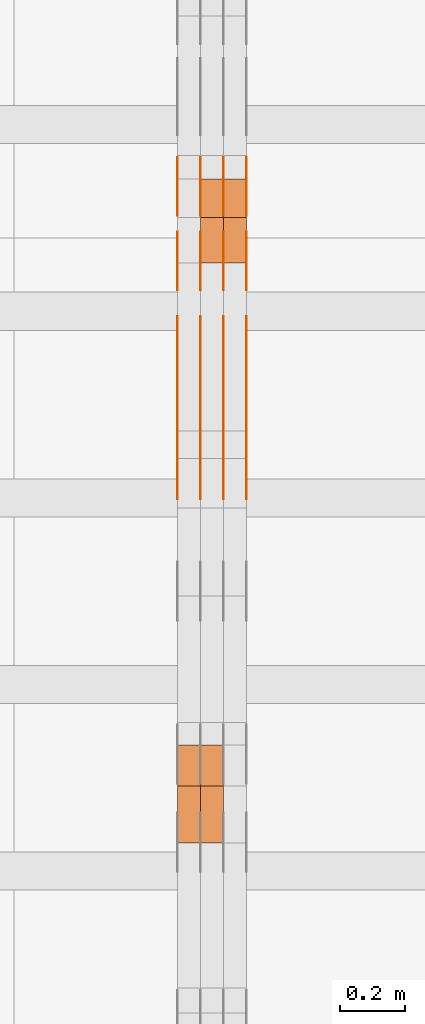
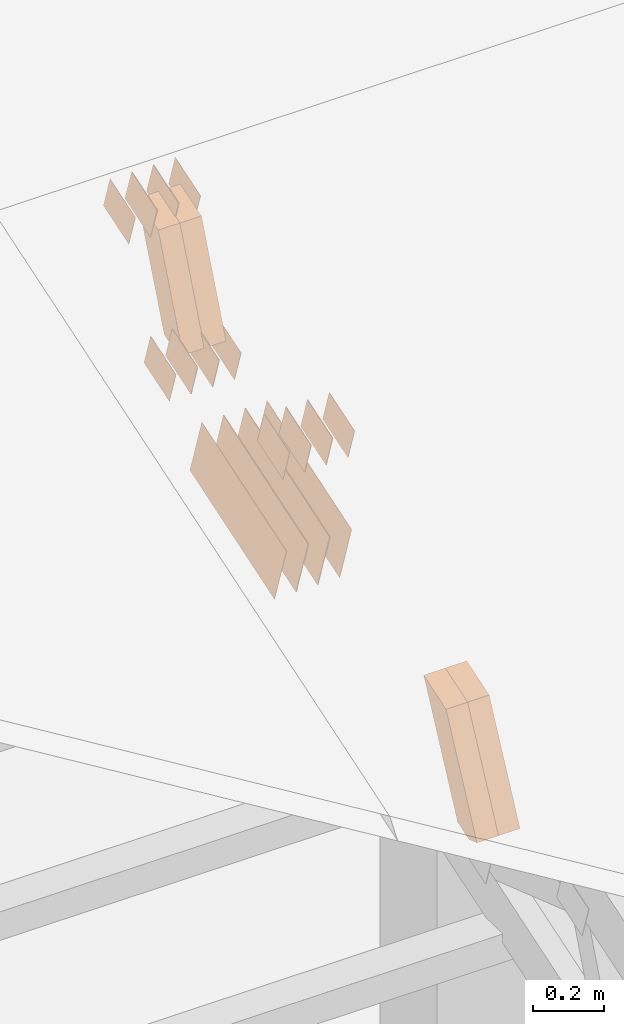
# One storey, part 257 of 385: 28 proxies.
"""IFC2X3 building model written with IfcOpenShell, lengths in millimetres."""

import ifcopenshell
import ifcopenshell.guid

model = None  # the IFC model being written
_history = None  # IfcOwnerHistory: only IFC2X3 demands one
_inside = {}  # id of a spatial element -> (the spatial element, [elements in it])
_under = {}  # id of a project, library or spatial element -> (it, [spatial elements below it])
_declared = {}  # id of a project -> (the project, [libraries it declares])
_typed = {}  # id of a type object -> (the type object, [elements of that type])
_made_of = {}  # id of a material, layer set ... -> (it, [elements and type objects made of it])


def new_model(schema):
    """Start an empty IFC model of exactly this schema.

    Asked for "IFC4X3", IfcOpenShell would pick the latest addendum, in which some entities
    have other attributes; the version numbers below select the first issue.
    IFC2X3 requires an IfcOwnerHistory on every rooted entity: one is made here for all.
    """
    global model, _history
    if schema == "IFC4X3":
        model = ifcopenshell.file(schema_version=(4, 3, 0, 0))
    else:
        model = ifcopenshell.file(schema=schema)
    _inside.clear()
    _under.clear()
    _declared.clear()
    _typed.clear()
    _made_of.clear()
    _history = None
    if model.schema == "IFC2X3":
        org = make("IfcOrganization", Name="unknown")
        user = make(
            "IfcPersonAndOrganization",
            ThePerson=make("IfcPerson", FamilyName="unknown"),
            TheOrganization=org,
        )
        app = make(
            "IfcApplication",
            ApplicationDeveloper=org,
            Version="unknown",
            ApplicationFullName="unknown",
            ApplicationIdentifier="unknown",
        )
        _history = make(
            "IfcOwnerHistory",
            OwningUser=user,
            OwningApplication=app,
            ChangeAction="ADDED",
            CreationDate=0,
        )
    return model


def make(cls, **values):
    """One entity of the class cls with the attributes given. An attribute that is None is left unset."""
    return model.create_entity(
        cls, **{name: value for name, value in values.items() if value is not None}
    )


def entity(cls, *values):
    """Any entity or typed value of the class cls, its attributes in the order of the schema. None: left unset."""
    e = model.create_entity(cls)
    for i, value in enumerate(values):
        if value is not None:
            e[i] = value
    return e


def rooted(cls, **values):
    """An entity with a GlobalId (a new one), such as an element, a storey or a relation."""
    return make(cls, GlobalId=ifcopenshell.guid.new(), OwnerHistory=_history, **values)


def si_unit(unit_type, name, prefix=None):
    """IfcSIUnit, for example si_unit("LENGTHUNIT", "METRE", prefix="MILLI")."""
    return make("IfcSIUnit", UnitType=unit_type, Prefix=prefix, Name=name)


def converted_unit(unit_type, name, factor, base, dimensions=None, offset=None):
    """IfcConversionBasedUnit, such as the inch: factor (a typed value) times the base unit."""
    return make(
        "IfcConversionBasedUnit"
        if offset is None
        else "IfcConversionBasedUnitWithOffset",
        ConversionOffset=offset,
        Dimensions=None
        if dimensions is None
        else entity("IfcDimensionalExponents", *dimensions),
        UnitType=unit_type,
        Name=name,
        ConversionFactor=make(
            "IfcMeasureWithUnit", ValueComponent=factor, UnitComponent=base
        ),
    )


def derived_unit(unit_type, elements):
    """IfcDerivedUnit: a product of units, each with its exponent."""
    return make(
        "IfcDerivedUnit",
        Elements=[
            make("IfcDerivedUnitElement", Unit=unit, Exponent=power)
            for unit, power in elements
        ],
        UnitType=unit_type,
    )


def assignment(units):
    """IfcUnitAssignment: the units of a project."""
    return None if units is None else make("IfcUnitAssignment", Units=units)


def point(xyz):
    """IfcCartesianPoint."""
    return None if xyz is None else make("IfcCartesianPoint", Coordinates=xyz)


def direction(xyz):
    """IfcDirection."""
    return None if xyz is None else make("IfcDirection", DirectionRatios=xyz)


def frame(location, z_axis=None, x_axis=None):
    """IfcAxis2Placement3D, a coordinate frame: its origin and axes. An axis left out is left unset."""
    return make(
        "IfcAxis2Placement3D",
        Location=point(location),
        Axis=direction(z_axis),
        RefDirection=direction(x_axis),
    )


def origin():
    """The frame at (0, 0, 0) with its axes left unset."""
    return frame((0.0, 0.0, 0.0))


def place(relative_to, where):
    """IfcLocalPlacement: puts the frame where relative to a parent placement (None: the world)."""
    return make(
        "IfcLocalPlacement", PlacementRelTo=relative_to, RelativePlacement=where
    )


def context(
    kind, dimensions, precision=None, world=None, true_north=None, identifier=None
):
    """IfcGeometricRepresentationContext, for example the 3D "Model" context."""
    return make(
        "IfcGeometricRepresentationContext",
        ContextIdentifier=identifier,
        ContextType=kind,
        CoordinateSpaceDimension=dimensions,
        Precision=precision,
        WorldCoordinateSystem=world,
        TrueNorth=true_north,
    )


def subcontext(parent, identifier, kind, view, scale=None):
    """IfcGeometricRepresentationSubContext, for example "Body" below "Model"."""
    return make(
        "IfcGeometricRepresentationSubContext",
        ContextIdentifier=identifier,
        ContextType=kind,
        ParentContext=parent,
        TargetScale=scale,
        TargetView=view,
    )


def project(units=None, contexts=None):
    """IfcProject with its units and contexts."""
    return rooted(
        "IfcProject",
        Name="project",
        RepresentationContexts=contexts,
        UnitsInContext=assignment(units),
    )


def spatial(cls, under=None, at=None, **own):
    """A site, building, storey or space (cls), placed at a placement, below another one or the project."""
    s = rooted(cls, ObjectPlacement=at, **own)
    if under is not None:
        _under.setdefault(under.id(), (under, []))[1].append(s)
    return s


def polyline(points):
    """IfcPolyline through the points."""
    return make("IfcPolyline", Points=[point(p) for p in points])


def outline(outer, holes=None, kind="AREA"):
    """IfcArbitraryClosedProfileDef: a profile drawn as a closed curve; with holes, ...WithVoids."""
    if holes is None:
        return make("IfcArbitraryClosedProfileDef", ProfileType=kind, OuterCurve=outer)
    return make(
        "IfcArbitraryProfileDefWithVoids",
        ProfileType=kind,
        OuterCurve=outer,
        InnerCurves=holes,
    )


def extrude(swept, where, along, depth):
    """IfcExtrudedAreaSolid: the profile swept, set in the frame where, extruded along a direction by depth."""
    return make(
        "IfcExtrudedAreaSolid",
        SweptArea=swept,
        Position=where,
        ExtrudedDirection=direction(along),
        Depth=depth,
    )


def shape(context_of_items, identifier, shape_type, items):
    """IfcShapeRepresentation: the items that make up one representation, for example the "Body"."""
    return make(
        "IfcShapeRepresentation",
        ContextOfItems=context_of_items,
        RepresentationIdentifier=identifier,
        RepresentationType=shape_type,
        Items=items,
    )


def source(mapping_origin, context_of_items, identifier, shape_type, items):
    """IfcRepresentationMap: a shape defined once, which mapped items show again and again."""
    return make(
        "IfcRepresentationMap",
        MappingOrigin=mapping_origin,
        MappedRepresentation=shape(context_of_items, identifier, shape_type, items),
    )


def transform(
    local_origin,
    x_axis=None,
    y_axis=None,
    z_axis=None,
    scale=None,
    scale2=None,
    scale3=None,
    uniform=True,
):
    """IfcCartesianTransformationOperator3D, or its non-uniform kind. x_axis, y_axis, z_axis: its Axis1, 2, 3."""
    if uniform:
        return make(
            "IfcCartesianTransformationOperator3D",
            Axis1=direction(x_axis),
            Axis2=direction(y_axis),
            LocalOrigin=point(local_origin),
            Scale=scale,
            Axis3=direction(z_axis),
        )
    return make(
        "IfcCartesianTransformationOperator3DnonUniform",
        Axis1=direction(x_axis),
        Axis2=direction(y_axis),
        LocalOrigin=point(local_origin),
        Scale=scale,
        Axis3=direction(z_axis),
        Scale2=scale2,
        Scale3=scale3,
    )


def mapped(mapping_source, mapping_target):
    """IfcMappedItem: shows the shape of a source again, moved by a transform."""
    return make(
        "IfcMappedItem", MappingSource=mapping_source, MappingTarget=mapping_target
    )


def material(Name=None, Category=None):
    """IfcMaterial."""
    return make("IfcMaterial", Name=Name, Category=Category)


def made_of(thing, what):
    """Note that an element or type object is made of a material, layer set ...; save() writes the relation."""
    if what is not None:
        _made_of.setdefault(what.id(), (what, []))[1].append(thing)
    return thing


def type_object(cls, material=None, **own):
    """A type object (cls), such as IfcWallType, which elements share."""
    return made_of(rooted(cls, **own), material)


def type_shapes(of_type, sources):
    """Give a type object the sources (RepresentationMaps) that its elements show as mapped items."""
    of_type.RepresentationMaps = sources


def element(
    cls,
    number,
    at=None,
    inside=None,
    cuts=None,
    type_object=None,
    material=None,
    context=None,
    identifier="Body",
    shape_type=None,
    held_by="IfcProductDefinitionShape",
    body=None,
    shapes=None,
    **own,
):
    """One element of the class cls, such as IfcWall. Its Tag is "e" and its number.

    at: its placement. inside: the storey or other place that contains it. cuts: it is an
    opening in that element (IfcRelVoidsElement). A single representation is given by context,
    identifier, shape_type and body (its items); several are given by shapes. held_by: the class
    of the entity that holds the representations. save() writes the other relations.
    """
    e = rooted(cls, Tag="e%d" % number, ObjectPlacement=at, **own)
    if body is not None:
        shapes = [shape(context, identifier, shape_type, body)]
    if shapes is not None:
        e.Representation = make(held_by, Representations=shapes)
    if inside is not None:
        _inside.setdefault(inside.id(), (inside, []))[1].append(e)
    if cuts is not None:
        rooted(
            "IfcRelVoidsElement", RelatingBuildingElement=cuts, RelatedOpeningElement=e
        )
    if type_object is not None:
        _typed.setdefault(type_object.id(), (type_object, []))[1].append(e)
    return made_of(e, material)


def aggregate(whole, parts):
    """IfcRelAggregates: a whole, such as a stair, and the parts it consists of."""
    return rooted("IfcRelAggregates", RelatingObject=whole, RelatedObjects=parts)


def save(model, path):
    """Write the relations noted so far, then the file.

    IfcRelAggregates (storeys below a building ...), IfcRelContainedInSpatialStructure (elements
    in a storey), IfcRelDefinesByType, IfcRelAssociatesMaterial and IfcRelDeclares: one each for
    every whole, place, type object, material and project.
    """
    for whole, parts in _under.values():
        aggregate(whole, parts)
    for where, things in _inside.values():
        rooted(
            "IfcRelContainedInSpatialStructure",
            RelatedElements=things,
            RelatingStructure=where,
        )
    for kind, things in _typed.values():
        rooted("IfcRelDefinesByType", RelatedObjects=things, RelatingType=kind)
    for what, things in _made_of.values():
        rooted("IfcRelAssociatesMaterial", RelatedObjects=things, RelatingMaterial=what)
    for by, libraries in _declared.values():
        rooted("IfcRelDeclares", RelatingContext=by, RelatedDefinitions=libraries)
    model.write(path)


model = new_model("IFC2X3")

# Units and contexts
model_context = context("Model", 3, precision=0.01, world=origin(), true_north=direction((6.12303176911189e-17, 1.0)))
body_context = subcontext(model_context, "Body", "Model", "MODEL_VIEW")
ifc_project = project(units=[si_unit("LENGTHUNIT", "METRE", prefix="MILLI"), si_unit("AREAUNIT", "SQUARE_METRE"), si_unit("VOLUMEUNIT", "CUBIC_METRE"), converted_unit("PLANEANGLEUNIT", "DEGREE", entity("IfcRatioMeasure", 0.0174532925199433), si_unit("PLANEANGLEUNIT", "RADIAN"), dimensions=[0, 0, 0, 0, 0, 0, 0]), si_unit("MASSUNIT", "GRAM", prefix="KILO"), derived_unit("MASSDENSITYUNIT", [(si_unit("MASSUNIT", "GRAM", prefix="KILO"), 1), (si_unit("LENGTHUNIT", "METRE"), -3)]), si_unit("TIMEUNIT", "SECOND"), si_unit("FREQUENCYUNIT", "HERTZ"), si_unit("THERMODYNAMICTEMPERATUREUNIT", "DEGREE_CELSIUS"), derived_unit("THERMALTRANSMITTANCEUNIT", [(si_unit("MASSUNIT", "GRAM", prefix="KILO"), 1), (si_unit("THERMODYNAMICTEMPERATUREUNIT", "KELVIN"), -1), (si_unit("TIMEUNIT", "SECOND"), -3)]), derived_unit("VOLUMETRICFLOWRATEUNIT", [(si_unit("LENGTHUNIT", "METRE"), 3), (si_unit("TIMEUNIT", "SECOND"), -1)]), si_unit("ELECTRICCURRENTUNIT", "AMPERE"), si_unit("ELECTRICVOLTAGEUNIT", "VOLT"), si_unit("POWERUNIT", "WATT"), si_unit("FORCEUNIT", "NEWTON", prefix="KILO"), si_unit("ILLUMINANCEUNIT", "LUX"), si_unit("LUMINOUSFLUXUNIT", "LUMEN"), si_unit("LUMINOUSINTENSITYUNIT", "CANDELA"), derived_unit("USERDEFINED", [(si_unit("MASSUNIT", "GRAM", prefix="KILO"), -1), (si_unit("LENGTHUNIT", "METRE"), -2), (si_unit("TIMEUNIT", "SECOND"), 3), (si_unit("LUMINOUSFLUXUNIT", "LUMEN"), 1)]), derived_unit("LINEARVELOCITYUNIT", [(si_unit("LENGTHUNIT", "METRE"), 1), (si_unit("TIMEUNIT", "SECOND"), -1)]), si_unit("PRESSUREUNIT", "PASCAL"), derived_unit("USERDEFINED", [(si_unit("LENGTHUNIT", "METRE"), -2), (si_unit("MASSUNIT", "GRAM", prefix="KILO"), 1), (si_unit("TIMEUNIT", "SECOND"), -2)])], contexts=[model_context])

# Site, building, storey
site_placement = place(None, origin())
site = spatial("IfcSite", under=ifc_project, at=site_placement, CompositionType="ELEMENT")
building_placement = place(site_placement, origin())
building = spatial("IfcBuilding", under=site, at=building_placement, CompositionType="ELEMENT")
storey_placement = place(building_placement, origin())
storey = spatial("IfcBuildingStorey", under=building, at=storey_placement, Name="Default", CompositionType="ELEMENT", Elevation=0.0)

# Proxies
ifc_material_1 = material(Name="IfcSurfaceStyle #453926")
building_element_proxy_type_1 = type_object("IfcBuildingElementProxyType", PredefinedType="NOTDEFINED", material=ifc_material_1)
shared_shape_1 = source(origin(), body_context, "Body", "SweptSolid", [
    extrude(outline(polyline([(-74.9998565677179, -60.000059685226), (74.9998794200128, -60.000059685226), (74.9998565677179, 60.000059685226), (-74.9998794200128, 60.000059685226), (-74.9998565677179, -60.000059685226)])), frame((75.0001976720505, 60.000059685226, 0.0), z_axis=(0.0, 0.0, 1.0), x_axis=(-1.0, 0.0, 0.0)), (0.0, 0.0, 1.0), 1.3),
])
type_shapes(building_element_proxy_type_1, [shared_shape_1])
proxy_1_placement = place(building_placement, frame((36386.3, 8537.53090236182, 1950.11166041942), z_axis=(-1.0, 0.0, 0.0), x_axis=(0.0, 0.951056516295124, 0.309016994375039)))
element("IfcBuildingElementProxy", 1, at=proxy_1_placement, inside=storey, type_object=building_element_proxy_type_1, material=ifc_material_1, context=body_context, shape_type="MappedRepresentation", body=[
    mapped(shared_shape_1, transform((0.0, 0.0, 0.0), scale=1.0)),
])
ifc_material_2 = material(Name="IfcSurfaceStyle #453869")
building_element_proxy_type_2 = type_object("IfcBuildingElementProxyType", PredefinedType="NOTDEFINED", material=ifc_material_2)
shared_shape_2 = source(origin(), body_context, "Body", "SweptSolid", [
    extrude(outline(polyline([(-74.9998565677179, -60.000059685226), (74.9998794200128, -60.000059685226), (74.9998565677179, 60.000059685226), (-74.9998794200128, 60.000059685226), (-74.9998565677179, -60.000059685226)])), frame((75.0001976720505, 60.000059685226, 0.0), z_axis=(0.0, 0.0, 1.0), x_axis=(-1.0, 0.0, 0.0)), (0.0, 0.0, 1.0), 1.3),
])
type_shapes(building_element_proxy_type_2, [shared_shape_2])
proxy_2_placement = place(building_placement, frame((36315.0, 8537.53090236182, 1950.11166041942), z_axis=(-1.0, 0.0, 0.0), x_axis=(0.0, 0.951056516295124, 0.309016994375039)))
element("IfcBuildingElementProxy", 2, at=proxy_2_placement, inside=storey, type_object=building_element_proxy_type_2, material=ifc_material_2, context=body_context, shape_type="MappedRepresentation", body=[
    mapped(shared_shape_2, transform((0.0, 0.0, 0.0), scale=1.0)),
])
ifc_material_3 = material(Name="IfcSurfaceStyle #453812")
building_element_proxy_type_3 = type_object("IfcBuildingElementProxyType", PredefinedType="NOTDEFINED", material=ifc_material_3)
shared_shape_3 = source(origin(), body_context, "Body", "SweptSolid", [
    extrude(outline(polyline([(-74.9998565677179, -60.000059685226), (74.9998794200128, -60.000059685226), (74.9998565677179, 60.000059685226), (-74.9998794200128, 60.000059685226), (-74.9998565677179, -60.000059685226)])), frame((75.0001976720505, 60.000059685226, 0.0), z_axis=(0.0, 0.0, 1.0), x_axis=(-1.0, 0.0, 0.0)), (0.0, 0.0, 1.0), 1.3),
])
type_shapes(building_element_proxy_type_3, [shared_shape_3])
proxy_3_placement = place(building_placement, frame((36316.3, 8537.53090236182, 1950.11166041942), z_axis=(-1.0, 0.0, 0.0), x_axis=(0.0, 0.951056516295124, 0.309016994375039)))
element("IfcBuildingElementProxy", 3, at=proxy_3_placement, inside=storey, type_object=building_element_proxy_type_3, material=ifc_material_3, context=body_context, shape_type="MappedRepresentation", body=[
    mapped(shared_shape_3, transform((0.0, 0.0, 0.0), scale=1.0)),
])
ifc_material_4 = material(Name="IfcSurfaceStyle #453755")
building_element_proxy_type_4 = type_object("IfcBuildingElementProxyType", PredefinedType="NOTDEFINED", material=ifc_material_4)
shared_shape_4 = source(origin(), body_context, "Body", "SweptSolid", [
    extrude(outline(polyline([(-74.9998565677179, -60.000059685226), (74.9998794200128, -60.000059685226), (74.9998565677179, 60.000059685226), (-74.9998794200128, 60.000059685226), (-74.9998565677179, -60.000059685226)])), frame((75.0001976720505, 60.000059685226, 0.0), z_axis=(0.0, 0.0, 1.0), x_axis=(-1.0, 0.0, 0.0)), (0.0, 0.0, 1.0), 1.29999999999999),
])
type_shapes(building_element_proxy_type_4, [shared_shape_4])
proxy_4_placement = place(building_placement, frame((36245.0, 8537.53090236182, 1950.11166041942), z_axis=(-1.0, 0.0, 0.0), x_axis=(0.0, 0.951056516295124, 0.309016994375039)))
element("IfcBuildingElementProxy", 4, at=proxy_4_placement, inside=storey, type_object=building_element_proxy_type_4, material=ifc_material_4, context=body_context, shape_type="MappedRepresentation", body=[
    mapped(shared_shape_4, transform((0.0, 0.0, 0.0), scale=1.0)),
])
ifc_material_5 = material(Name="IfcSurfaceStyle #453698")
building_element_proxy_type_5 = type_object("IfcBuildingElementProxyType", PredefinedType="NOTDEFINED", material=ifc_material_5)
shared_shape_5 = source(origin(), body_context, "Body", "SweptSolid", [
    extrude(outline(polyline([(-74.9998565677179, -60.000059685226), (74.9998794200128, -60.000059685226), (74.9998565677179, 60.000059685226), (-74.9998794200128, 60.000059685226), (-74.9998565677179, -60.000059685226)])), frame((75.0001976720505, 60.000059685226, 0.0), z_axis=(0.0, 0.0, 1.0), x_axis=(-1.0, 0.0, 0.0)), (0.0, 0.0, 1.0), 1.29999999999999),
])
type_shapes(building_element_proxy_type_5, [shared_shape_5])
proxy_5_placement = place(building_placement, frame((36246.3, 8537.53090236182, 1950.11166041942), z_axis=(-1.0, 0.0, 0.0), x_axis=(0.0, 0.951056516295124, 0.309016994375039)))
element("IfcBuildingElementProxy", 5, at=proxy_5_placement, inside=storey, type_object=building_element_proxy_type_5, material=ifc_material_5, context=body_context, shape_type="MappedRepresentation", body=[
    mapped(shared_shape_5, transform((0.0, 0.0, 0.0), scale=1.0)),
])
ifc_material_6 = material(Name="IfcSurfaceStyle #453641")
building_element_proxy_type_6 = type_object("IfcBuildingElementProxyType", PredefinedType="NOTDEFINED", material=ifc_material_6)
shared_shape_6 = source(origin(), body_context, "Body", "SweptSolid", [
    extrude(outline(polyline([(-74.9998565677179, -60.000059685226), (74.9998794200128, -60.000059685226), (74.9998565677179, 60.000059685226), (-74.9998794200128, 60.000059685226), (-74.9998565677179, -60.000059685226)])), frame((75.0001976720505, 60.000059685226, 0.0), z_axis=(0.0, 0.0, 1.0), x_axis=(-1.0, 0.0, 0.0)), (0.0, 0.0, 1.0), 1.29999999999999),
])
type_shapes(building_element_proxy_type_6, [shared_shape_6])
proxy_6_placement = place(building_placement, frame((36175.0, 8537.53090236182, 1950.11166041942), z_axis=(-1.0, 0.0, 0.0), x_axis=(0.0, 0.951056516295124, 0.309016994375039)))
element("IfcBuildingElementProxy", 6, at=proxy_6_placement, inside=storey, type_object=building_element_proxy_type_6, material=ifc_material_6, context=body_context, shape_type="MappedRepresentation", body=[
    mapped(shared_shape_6, transform((0.0, 0.0, 0.0), scale=1.0)),
])
ifc_material_7 = material(Name="IfcSurfaceStyle #453584")
building_element_proxy_type_7 = type_object("IfcBuildingElementProxyType", PredefinedType="NOTDEFINED", material=ifc_material_7)
shared_shape_7 = source(origin(), body_context, "Body", "SweptSolid", [
    extrude(outline(polyline([(-74.9998754286225, -60.0000016373515), (74.9998605591045, -60.0000016373515), (74.9998754286225, 60.0000016373515), (-74.9998605591045, 60.0000016373515), (-74.9998754286225, -60.0000016373515)])), frame((74.9998754286225, 60.0000016373515, 0.0), z_axis=(0.0, 0.0, 1.0), x_axis=(-1.0, 0.0, 0.0)), (0.0, 0.0, 1.0), 1.3),
])
type_shapes(building_element_proxy_type_7, [shared_shape_7])
proxy_7_placement = place(building_placement, frame((36386.3, 8765.47458614632, 2350.86432930304), z_axis=(-1.0, 0.0, 0.0), x_axis=(0.0, 0.951056516295154, 0.309016994374948)))
element("IfcBuildingElementProxy", 7, at=proxy_7_placement, inside=storey, type_object=building_element_proxy_type_7, material=ifc_material_7, context=body_context, shape_type="MappedRepresentation", body=[
    mapped(shared_shape_7, transform((0.0, 0.0, 0.0), scale=1.0)),
])
ifc_material_8 = material(Name="IfcSurfaceStyle #453527")
building_element_proxy_type_8 = type_object("IfcBuildingElementProxyType", PredefinedType="NOTDEFINED", material=ifc_material_8)
shared_shape_8 = source(origin(), body_context, "Body", "SweptSolid", [
    extrude(outline(polyline([(-74.9998754286225, -60.0000016373515), (74.9998605591045, -60.0000016373515), (74.9998754286225, 60.0000016373515), (-74.9998605591045, 60.0000016373515), (-74.9998754286225, -60.0000016373515)])), frame((74.9998754286225, 60.0000016373515, 0.0), z_axis=(0.0, 0.0, 1.0), x_axis=(-1.0, 0.0, 0.0)), (0.0, 0.0, 1.0), 1.3),
])
type_shapes(building_element_proxy_type_8, [shared_shape_8])
proxy_8_placement = place(building_placement, frame((36315.0, 8765.47458614632, 2350.86432930304), z_axis=(-1.0, 0.0, 0.0), x_axis=(0.0, 0.951056516295154, 0.309016994374948)))
element("IfcBuildingElementProxy", 8, at=proxy_8_placement, inside=storey, type_object=building_element_proxy_type_8, material=ifc_material_8, context=body_context, shape_type="MappedRepresentation", body=[
    mapped(shared_shape_8, transform((0.0, 0.0, 0.0), scale=1.0)),
])
ifc_material_9 = material(Name="IfcSurfaceStyle #453470")
building_element_proxy_type_9 = type_object("IfcBuildingElementProxyType", PredefinedType="NOTDEFINED", material=ifc_material_9)
shared_shape_9 = source(origin(), body_context, "Body", "SweptSolid", [
    extrude(outline(polyline([(-74.9998754286225, -60.0000016373515), (74.9998605591045, -60.0000016373515), (74.9998754286225, 60.0000016373515), (-74.9998605591045, 60.0000016373515), (-74.9998754286225, -60.0000016373515)])), frame((74.9998754286225, 60.0000016373515, 0.0), z_axis=(0.0, 0.0, 1.0), x_axis=(-1.0, 0.0, 0.0)), (0.0, 0.0, 1.0), 1.3),
])
type_shapes(building_element_proxy_type_9, [shared_shape_9])
proxy_9_placement = place(building_placement, frame((36316.3, 8765.47458614632, 2350.86432930304), z_axis=(-1.0, 0.0, 0.0), x_axis=(0.0, 0.951056516295154, 0.309016994374948)))
element("IfcBuildingElementProxy", 9, at=proxy_9_placement, inside=storey, type_object=building_element_proxy_type_9, material=ifc_material_9, context=body_context, shape_type="MappedRepresentation", body=[
    mapped(shared_shape_9, transform((0.0, 0.0, 0.0), scale=1.0)),
])
ifc_material_10 = material(Name="IfcSurfaceStyle #453413")
building_element_proxy_type_10 = type_object("IfcBuildingElementProxyType", PredefinedType="NOTDEFINED", material=ifc_material_10)
shared_shape_10 = source(origin(), body_context, "Body", "SweptSolid", [
    extrude(outline(polyline([(-74.9998754286225, -60.0000016373515), (74.9998605591045, -60.0000016373515), (74.9998754286225, 60.0000016373515), (-74.9998605591045, 60.0000016373515), (-74.9998754286225, -60.0000016373515)])), frame((74.9998754286225, 60.0000016373515, 0.0), z_axis=(0.0, 0.0, 1.0), x_axis=(-1.0, 0.0, 0.0)), (0.0, 0.0, 1.0), 1.29999999999999),
])
type_shapes(building_element_proxy_type_10, [shared_shape_10])
proxy_10_placement = place(building_placement, frame((36245.0, 8765.47458614632, 2350.86432930304), z_axis=(-1.0, 0.0, 0.0), x_axis=(0.0, 0.951056516295154, 0.309016994374948)))
element("IfcBuildingElementProxy", 10, at=proxy_10_placement, inside=storey, type_object=building_element_proxy_type_10, material=ifc_material_10, context=body_context, shape_type="MappedRepresentation", body=[
    mapped(shared_shape_10, transform((0.0, 0.0, 0.0), scale=1.0)),
])
ifc_material_11 = material(Name="IfcSurfaceStyle #453356")
building_element_proxy_type_11 = type_object("IfcBuildingElementProxyType", PredefinedType="NOTDEFINED", material=ifc_material_11)
shared_shape_11 = source(origin(), body_context, "Body", "SweptSolid", [
    extrude(outline(polyline([(-74.9998754286225, -60.0000016373515), (74.9998605591045, -60.0000016373515), (74.9998754286225, 60.0000016373515), (-74.9998605591045, 60.0000016373515), (-74.9998754286225, -60.0000016373515)])), frame((74.9998754286225, 60.0000016373515, 0.0), z_axis=(0.0, 0.0, 1.0), x_axis=(-1.0, 0.0, 0.0)), (0.0, 0.0, 1.0), 1.29999999999999),
])
type_shapes(building_element_proxy_type_11, [shared_shape_11])
proxy_11_placement = place(building_placement, frame((36246.3, 8765.47458614632, 2350.86432930304), z_axis=(-1.0, 0.0, 0.0), x_axis=(0.0, 0.951056516295154, 0.309016994374948)))
element("IfcBuildingElementProxy", 11, at=proxy_11_placement, inside=storey, type_object=building_element_proxy_type_11, material=ifc_material_11, context=body_context, shape_type="MappedRepresentation", body=[
    mapped(shared_shape_11, transform((0.0, 0.0, 0.0), scale=1.0)),
])
ifc_material_12 = material(Name="IfcSurfaceStyle #453299")
building_element_proxy_type_12 = type_object("IfcBuildingElementProxyType", PredefinedType="NOTDEFINED", material=ifc_material_12)
shared_shape_12 = source(origin(), body_context, "Body", "SweptSolid", [
    extrude(outline(polyline([(-74.9998754286225, -60.0000016373515), (74.9998605591045, -60.0000016373515), (74.9998754286225, 60.0000016373515), (-74.9998605591045, 60.0000016373515), (-74.9998754286225, -60.0000016373515)])), frame((74.9998754286225, 60.0000016373515, 0.0), z_axis=(0.0, 0.0, 1.0), x_axis=(-1.0, 0.0, 0.0)), (0.0, 0.0, 1.0), 1.29999999999999),
])
type_shapes(building_element_proxy_type_12, [shared_shape_12])
proxy_12_placement = place(building_placement, frame((36175.0, 8765.47458614632, 2350.86432930304), z_axis=(-1.0, 0.0, 0.0), x_axis=(0.0, 0.951056516295154, 0.309016994374948)))
element("IfcBuildingElementProxy", 12, at=proxy_12_placement, inside=storey, type_object=building_element_proxy_type_12, material=ifc_material_12, context=body_context, shape_type="MappedRepresentation", body=[
    mapped(shared_shape_12, transform((0.0, 0.0, 0.0), scale=1.0)),
])
ifc_material_13 = material(Name="IfcSurfaceStyle #452900")
building_element_proxy_type_13 = type_object("IfcBuildingElementProxyType", PredefinedType="NOTDEFINED", material=ifc_material_13)
shared_shape_13 = source(origin(), body_context, "Body", "SweptSolid", [
    extrude(outline(polyline([(-249.999749056184, -108.000229288163), (249.999396050782, -108.000229288163), (249.999749056184, 108.000229288163), (-249.999396050782, 108.000229288163), (-249.999749056184, -108.000229288163)])), frame((249.999841104007, 108.000229288163, 0.0), z_axis=(0.0, 0.0, 1.0), x_axis=(-1.0, 0.0, 0.0)), (0.0, 0.0, 1.0), 1.29999999999998),
])
type_shapes(building_element_proxy_type_13, [shared_shape_13])
proxy_13_placement = place(building_placement, frame((36386.3, 7917.13457673635, 1720.66532252899), z_axis=(-1.0, 0.0, 0.0), x_axis=(0.0, 0.951056516295124, 0.309016994375039)))
element("IfcBuildingElementProxy", 13, at=proxy_13_placement, inside=storey, type_object=building_element_proxy_type_13, material=ifc_material_13, context=body_context, shape_type="MappedRepresentation", body=[
    mapped(shared_shape_13, transform((0.0, 0.0, 0.0), scale=1.0)),
])
ifc_material_14 = material(Name="IfcSurfaceStyle #452843")
building_element_proxy_type_14 = type_object("IfcBuildingElementProxyType", PredefinedType="NOTDEFINED", material=ifc_material_14)
shared_shape_14 = source(origin(), body_context, "Body", "SweptSolid", [
    extrude(outline(polyline([(-249.999749056184, -108.000229288163), (249.999396050782, -108.000229288163), (249.999749056184, 108.000229288163), (-249.999396050782, 108.000229288163), (-249.999749056184, -108.000229288163)])), frame((249.999841104007, 108.000229288163, 0.0), z_axis=(0.0, 0.0, 1.0), x_axis=(-1.0, 0.0, 0.0)), (0.0, 0.0, 1.0), 1.29999999999998),
])
type_shapes(building_element_proxy_type_14, [shared_shape_14])
proxy_14_placement = place(building_placement, frame((36315.0, 7917.13457673635, 1720.66532252899), z_axis=(-1.0, 0.0, 0.0), x_axis=(0.0, 0.951056516295124, 0.309016994375039)))
element("IfcBuildingElementProxy", 14, at=proxy_14_placement, inside=storey, type_object=building_element_proxy_type_14, material=ifc_material_14, context=body_context, shape_type="MappedRepresentation", body=[
    mapped(shared_shape_14, transform((0.0, 0.0, 0.0), scale=1.0)),
])
ifc_material_15 = material(Name="IfcSurfaceStyle #452786")
building_element_proxy_type_15 = type_object("IfcBuildingElementProxyType", PredefinedType="NOTDEFINED", material=ifc_material_15)
shared_shape_15 = source(origin(), body_context, "Body", "SweptSolid", [
    extrude(outline(polyline([(-249.999749056184, -108.000229288163), (249.999396050782, -108.000229288163), (249.999749056184, 108.000229288163), (-249.999396050782, 108.000229288163), (-249.999749056184, -108.000229288163)])), frame((249.999841104007, 108.000229288163, 0.0), z_axis=(0.0, 0.0, 1.0), x_axis=(-1.0, 0.0, 0.0)), (0.0, 0.0, 1.0), 1.29999999999998),
])
type_shapes(building_element_proxy_type_15, [shared_shape_15])
proxy_15_placement = place(building_placement, frame((36316.3, 7917.13457673635, 1720.66532252899), z_axis=(-1.0, 0.0, 0.0), x_axis=(0.0, 0.951056516295124, 0.309016994375039)))
element("IfcBuildingElementProxy", 15, at=proxy_15_placement, inside=storey, type_object=building_element_proxy_type_15, material=ifc_material_15, context=body_context, shape_type="MappedRepresentation", body=[
    mapped(shared_shape_15, transform((0.0, 0.0, 0.0), scale=1.0)),
])
ifc_material_16 = material(Name="IfcSurfaceStyle #452729")
building_element_proxy_type_16 = type_object("IfcBuildingElementProxyType", PredefinedType="NOTDEFINED", material=ifc_material_16)
shared_shape_16 = source(origin(), body_context, "Body", "SweptSolid", [
    extrude(outline(polyline([(-249.999749056184, -108.000229288163), (249.999396050782, -108.000229288163), (249.999749056184, 108.000229288163), (-249.999396050782, 108.000229288163), (-249.999749056184, -108.000229288163)])), frame((249.999841104007, 108.000229288163, 0.0), z_axis=(0.0, 0.0, 1.0), x_axis=(-1.0, 0.0, 0.0)), (0.0, 0.0, 1.0), 1.29999999999997),
])
type_shapes(building_element_proxy_type_16, [shared_shape_16])
proxy_16_placement = place(building_placement, frame((36245.0, 7917.13457673635, 1720.66532252899), z_axis=(-1.0, 0.0, 0.0), x_axis=(0.0, 0.951056516295124, 0.309016994375039)))
element("IfcBuildingElementProxy", 16, at=proxy_16_placement, inside=storey, type_object=building_element_proxy_type_16, material=ifc_material_16, context=body_context, shape_type="MappedRepresentation", body=[
    mapped(shared_shape_16, transform((0.0, 0.0, 0.0), scale=1.0)),
])
ifc_material_17 = material(Name="IfcSurfaceStyle #452672")
building_element_proxy_type_17 = type_object("IfcBuildingElementProxyType", PredefinedType="NOTDEFINED", material=ifc_material_17)
shared_shape_17 = source(origin(), body_context, "Body", "SweptSolid", [
    extrude(outline(polyline([(-249.999749056184, -108.000229288163), (249.999396050782, -108.000229288163), (249.999749056184, 108.000229288163), (-249.999396050782, 108.000229288163), (-249.999749056184, -108.000229288163)])), frame((249.999841104007, 108.000229288163, 0.0), z_axis=(0.0, 0.0, 1.0), x_axis=(-1.0, 0.0, 0.0)), (0.0, 0.0, 1.0), 1.29999999999997),
])
type_shapes(building_element_proxy_type_17, [shared_shape_17])
proxy_17_placement = place(building_placement, frame((36246.3, 7917.13457673635, 1720.66532252899), z_axis=(-1.0, 0.0, 0.0), x_axis=(0.0, 0.951056516295124, 0.309016994375039)))
element("IfcBuildingElementProxy", 17, at=proxy_17_placement, inside=storey, type_object=building_element_proxy_type_17, material=ifc_material_17, context=body_context, shape_type="MappedRepresentation", body=[
    mapped(shared_shape_17, transform((0.0, 0.0, 0.0), scale=1.0)),
])
ifc_material_18 = material(Name="IfcSurfaceStyle #452615")
building_element_proxy_type_18 = type_object("IfcBuildingElementProxyType", PredefinedType="NOTDEFINED", material=ifc_material_18)
shared_shape_18 = source(origin(), body_context, "Body", "SweptSolid", [
    extrude(outline(polyline([(-249.999749056184, -108.000229288163), (249.999396050782, -108.000229288163), (249.999749056184, 108.000229288163), (-249.999396050782, 108.000229288163), (-249.999749056184, -108.000229288163)])), frame((249.999841104007, 108.000229288163, 0.0), z_axis=(0.0, 0.0, 1.0), x_axis=(-1.0, 0.0, 0.0)), (0.0, 0.0, 1.0), 1.29999999999997),
])
type_shapes(building_element_proxy_type_18, [shared_shape_18])
proxy_18_placement = place(building_placement, frame((36175.0, 7917.13457673635, 1720.66532252899), z_axis=(-1.0, 0.0, 0.0), x_axis=(0.0, 0.951056516295124, 0.309016994375039)))
element("IfcBuildingElementProxy", 18, at=proxy_18_placement, inside=storey, type_object=building_element_proxy_type_18, material=ifc_material_18, context=body_context, shape_type="MappedRepresentation", body=[
    mapped(shared_shape_18, transform((0.0, 0.0, 0.0), scale=1.0)),
])
ifc_material_19 = material(Name="IfcSurfaceStyle #439220")
building_element_proxy_type_19 = type_object("IfcBuildingElementProxyType", PredefinedType="NOTDEFINED", material=ifc_material_19)
shared_shape_19 = source(origin(), body_context, "Body", "SweptSolid", [
    extrude(outline(polyline([(-74.9998754286253, -60.0000016373506), (74.9998605591091, -60.0000016373506), (74.9998754286234, 60.0000016373506), (-74.9998605591072, 60.0000016373506), (-74.9998754286253, -60.0000016373506)])), frame((75.0007355357002, 60.0002637031812, 0.0), z_axis=(0.0, 0.0, 1.0), x_axis=(-1.0, 0.0, 0.0)), (0.0, 0.0, 1.0), 1.3),
])
type_shapes(building_element_proxy_type_19, [shared_shape_19])
proxy_19_placement = place(building_placement, frame((36386.3, 7899.79204652808, 2069.58672486412), z_axis=(-1.0, 0.0, 0.0), x_axis=(0.0, 0.951056516295154, 0.309016994374948)))
element("IfcBuildingElementProxy", 19, at=proxy_19_placement, inside=storey, type_object=building_element_proxy_type_19, material=ifc_material_19, context=body_context, shape_type="MappedRepresentation", body=[
    mapped(shared_shape_19, transform((0.0, 0.0, 0.0), scale=1.0)),
])
ifc_material_20 = material(Name="IfcSurfaceStyle #439163")
building_element_proxy_type_20 = type_object("IfcBuildingElementProxyType", PredefinedType="NOTDEFINED", material=ifc_material_20)
shared_shape_20 = source(origin(), body_context, "Body", "SweptSolid", [
    extrude(outline(polyline([(-74.9998754286253, -60.0000016373506), (74.9998605591091, -60.0000016373506), (74.9998754286234, 60.0000016373506), (-74.9998605591072, 60.0000016373506), (-74.9998754286253, -60.0000016373506)])), frame((75.0007355357002, 60.0002637031812, 0.0), z_axis=(0.0, 0.0, 1.0), x_axis=(-1.0, 0.0, 0.0)), (0.0, 0.0, 1.0), 1.3),
])
type_shapes(building_element_proxy_type_20, [shared_shape_20])
proxy_20_placement = place(building_placement, frame((36315.0, 7899.79204652808, 2069.58672486412), z_axis=(-1.0, 0.0, 0.0), x_axis=(0.0, 0.951056516295154, 0.309016994374948)))
element("IfcBuildingElementProxy", 20, at=proxy_20_placement, inside=storey, type_object=building_element_proxy_type_20, material=ifc_material_20, context=body_context, shape_type="MappedRepresentation", body=[
    mapped(shared_shape_20, transform((0.0, 0.0, 0.0), scale=1.0)),
])
ifc_material_21 = material(Name="IfcSurfaceStyle #439106")
building_element_proxy_type_21 = type_object("IfcBuildingElementProxyType", PredefinedType="NOTDEFINED", material=ifc_material_21)
shared_shape_21 = source(origin(), body_context, "Body", "SweptSolid", [
    extrude(outline(polyline([(-74.9998754286253, -60.0000016373506), (74.9998605591091, -60.0000016373506), (74.9998754286234, 60.0000016373506), (-74.9998605591072, 60.0000016373506), (-74.9998754286253, -60.0000016373506)])), frame((75.0007355357002, 60.0002637031812, 0.0), z_axis=(0.0, 0.0, 1.0), x_axis=(-1.0, 0.0, 0.0)), (0.0, 0.0, 1.0), 1.3),
])
type_shapes(building_element_proxy_type_21, [shared_shape_21])
proxy_21_placement = place(building_placement, frame((36316.3, 7899.79204652808, 2069.58672486412), z_axis=(-1.0, 0.0, 0.0), x_axis=(0.0, 0.951056516295154, 0.309016994374948)))
element("IfcBuildingElementProxy", 21, at=proxy_21_placement, inside=storey, type_object=building_element_proxy_type_21, material=ifc_material_21, context=body_context, shape_type="MappedRepresentation", body=[
    mapped(shared_shape_21, transform((0.0, 0.0, 0.0), scale=1.0)),
])
ifc_material_22 = material(Name="IfcSurfaceStyle #439049")
building_element_proxy_type_22 = type_object("IfcBuildingElementProxyType", PredefinedType="NOTDEFINED", material=ifc_material_22)
shared_shape_22 = source(origin(), body_context, "Body", "SweptSolid", [
    extrude(outline(polyline([(-74.9998754286253, -60.0000016373506), (74.9998605591091, -60.0000016373506), (74.9998754286234, 60.0000016373506), (-74.9998605591072, 60.0000016373506), (-74.9998754286253, -60.0000016373506)])), frame((75.0007355357002, 60.0002637031812, 0.0), z_axis=(0.0, 0.0, 1.0), x_axis=(-1.0, 0.0, 0.0)), (0.0, 0.0, 1.0), 1.29999999999999),
])
type_shapes(building_element_proxy_type_22, [shared_shape_22])
proxy_22_placement = place(building_placement, frame((36245.0, 7899.79204652808, 2069.58672486412), z_axis=(-1.0, 0.0, 0.0), x_axis=(0.0, 0.951056516295154, 0.309016994374948)))
element("IfcBuildingElementProxy", 22, at=proxy_22_placement, inside=storey, type_object=building_element_proxy_type_22, material=ifc_material_22, context=body_context, shape_type="MappedRepresentation", body=[
    mapped(shared_shape_22, transform((0.0, 0.0, 0.0), scale=1.0)),
])
ifc_material_23 = material(Name="IfcSurfaceStyle #438992")
building_element_proxy_type_23 = type_object("IfcBuildingElementProxyType", PredefinedType="NOTDEFINED", material=ifc_material_23)
shared_shape_23 = source(origin(), body_context, "Body", "SweptSolid", [
    extrude(outline(polyline([(-74.9998754286253, -60.0000016373506), (74.9998605591091, -60.0000016373506), (74.9998754286234, 60.0000016373506), (-74.9998605591072, 60.0000016373506), (-74.9998754286253, -60.0000016373506)])), frame((75.0007355357002, 60.0002637031812, 0.0), z_axis=(0.0, 0.0, 1.0), x_axis=(-1.0, 0.0, 0.0)), (0.0, 0.0, 1.0), 1.29999999999999),
])
type_shapes(building_element_proxy_type_23, [shared_shape_23])
proxy_23_placement = place(building_placement, frame((36246.3, 7899.79204652808, 2069.58672486412), z_axis=(-1.0, 0.0, 0.0), x_axis=(0.0, 0.951056516295154, 0.309016994374948)))
element("IfcBuildingElementProxy", 23, at=proxy_23_placement, inside=storey, type_object=building_element_proxy_type_23, material=ifc_material_23, context=body_context, shape_type="MappedRepresentation", body=[
    mapped(shared_shape_23, transform((0.0, 0.0, 0.0), scale=1.0)),
])
ifc_material_24 = material(Name="IfcSurfaceStyle #438935")
building_element_proxy_type_24 = type_object("IfcBuildingElementProxyType", PredefinedType="NOTDEFINED", material=ifc_material_24)
shared_shape_24 = source(origin(), body_context, "Body", "SweptSolid", [
    extrude(outline(polyline([(-74.9998754286253, -60.0000016373506), (74.9998605591091, -60.0000016373506), (74.9998754286234, 60.0000016373506), (-74.9998605591072, 60.0000016373506), (-74.9998754286253, -60.0000016373506)])), frame((75.0007355357002, 60.0002637031812, 0.0), z_axis=(0.0, 0.0, 1.0), x_axis=(-1.0, 0.0, 0.0)), (0.0, 0.0, 1.0), 1.29999999999999),
])
type_shapes(building_element_proxy_type_24, [shared_shape_24])
proxy_24_placement = place(building_placement, frame((36175.0, 7899.79204652808, 2069.58672486412), z_axis=(-1.0, 0.0, 0.0), x_axis=(0.0, 0.951056516295154, 0.309016994374948)))
element("IfcBuildingElementProxy", 24, at=proxy_24_placement, inside=storey, type_object=building_element_proxy_type_24, material=ifc_material_24, context=body_context, shape_type="MappedRepresentation", body=[
    mapped(shared_shape_24, transform((0.0, 0.0, 0.0), scale=1.0)),
])
ifc_material_25 = material(Name="IfcSurfaceStyle #426836")
building_element_proxy_type_25 = type_object("IfcBuildingElementProxyType", Name="T1-W45 426834", PredefinedType="NOTDEFINED", material=ifc_material_25)
shared_shape_25 = source(origin(), body_context, "Body", "SweptSolid", [
    extrude(outline(polyline([(-275.953018340717, -47.500197738425), (128.971267956636, -47.5001977384251), (168.669977842085, -0.000132525443043008), (174.867371111815, 47.5002640011466), (-196.55559856982, 47.5002640011466), (-275.953018340717, -47.500197738425)])), frame((174.867371111815, 47.5002640011466, 0.0), z_axis=(0.0, 0.0, 1.0), x_axis=(-1.0, 0.0, 0.0)), (0.0, 0.0, 1.0), 70.0),
])
type_shapes(building_element_proxy_type_25, [shared_shape_25])
proxy_25_placement = place(building_placement, frame((36385.0, 8621.494140625, 1941.33422851563), z_axis=(-1.0, 0.0, 0.0), x_axis=(0.0, 0.372787901688292, 0.927916580493549)))
element("IfcBuildingElementProxy", 25, at=proxy_25_placement, inside=storey, type_object=building_element_proxy_type_25, material=ifc_material_25, Name="T1-W45", context=body_context, shape_type="MappedRepresentation", body=[
    mapped(shared_shape_25, transform((0.0, 0.0, 0.0), scale=1.0)),
])
ifc_material_26 = material(Name="IfcSurfaceStyle #426770")
building_element_proxy_type_26 = type_object("IfcBuildingElementProxyType", Name="T1-W45 426768", PredefinedType="NOTDEFINED", material=ifc_material_26)
shared_shape_26 = source(origin(), body_context, "Body", "SweptSolid", [
    extrude(outline(polyline([(-275.953018340717, -47.500197738425), (128.971267956636, -47.5001977384251), (168.669977842085, -0.000132525443043008), (174.867371111815, 47.5002640011466), (-196.55559856982, 47.5002640011466), (-275.953018340717, -47.500197738425)])), frame((174.867371111815, 47.5002640011466, 0.0), z_axis=(0.0, 0.0, 1.0), x_axis=(-1.0, 0.0, 0.0)), (0.0, 0.0, 1.0), 70.0),
])
type_shapes(building_element_proxy_type_26, [shared_shape_26])
proxy_26_placement = place(building_placement, frame((36315.0, 8621.494140625, 1941.33422851563), z_axis=(-1.0, 0.0, 0.0), x_axis=(0.0, 0.372787901688292, 0.927916580493549)))
element("IfcBuildingElementProxy", 26, at=proxy_26_placement, inside=storey, type_object=building_element_proxy_type_26, material=ifc_material_26, Name="T1-W45", context=body_context, shape_type="MappedRepresentation", body=[
    mapped(shared_shape_26, transform((0.0, 0.0, 0.0), scale=1.0)),
])
ifc_material_27 = material(Name="IfcSurfaceStyle #425186")
building_element_proxy_type_27 = type_object("IfcBuildingElementProxyType", Name="T1-W38 425184", PredefinedType="NOTDEFINED", material=ifc_material_27)
shared_shape_27 = source(origin(), body_context, "Body", "SweptSolid", [
    extrude(outline(polyline([(-298.027186733919, -47.5000251939178), (135.138415004037, -47.5000251939178), (181.282052802132, 0.000918984287993996), (187.347601017465, 47.4995657017738), (-205.740882089715, 47.4995657017739), (-298.027186733919, -47.5000251939178)])), frame((187.347846776827, 47.5001085012031, 0.0), z_axis=(0.0, 0.0, 1.0), x_axis=(-1.0, 0.0, 0.0)), (0.0, 0.0, 1.0), 70.0),
])
type_shapes(building_element_proxy_type_27, [shared_shape_27])
proxy_27_placement = place(building_placement, frame((36315.0, 6848.47987320449, 1368.44362234215), z_axis=(-1.0, 0.0, 0.0), x_axis=(0.0, 0.441034274474743, 0.897490261082836)))
element("IfcBuildingElementProxy", 27, at=proxy_27_placement, inside=storey, type_object=building_element_proxy_type_27, material=ifc_material_27, Name="T1-W38", context=body_context, shape_type="MappedRepresentation", body=[
    mapped(shared_shape_27, transform((0.0, 0.0, 0.0), scale=1.0)),
])
ifc_material_28 = material(Name="IfcSurfaceStyle #425120")
building_element_proxy_type_28 = type_object("IfcBuildingElementProxyType", Name="T1-W38 425118", PredefinedType="NOTDEFINED", material=ifc_material_28)
shared_shape_28 = source(origin(), body_context, "Body", "SweptSolid", [
    extrude(outline(polyline([(-298.027186733919, -47.5000251939178), (135.138415004037, -47.5000251939178), (181.282052802132, 0.000918984287993996), (187.347601017465, 47.4995657017738), (-205.740882089715, 47.4995657017739), (-298.027186733919, -47.5000251939178)])), frame((187.347846776827, 47.5001085012031, 0.0), z_axis=(0.0, 0.0, 1.0), x_axis=(-1.0, 0.0, 0.0)), (0.0, 0.0, 1.0), 70.0),
])
type_shapes(building_element_proxy_type_28, [shared_shape_28])
proxy_28_placement = place(building_placement, frame((36245.0, 6848.47987320449, 1368.44362234215), z_axis=(-1.0, 0.0, 0.0), x_axis=(0.0, 0.441034274474743, 0.897490261082836)))
element("IfcBuildingElementProxy", 28, at=proxy_28_placement, inside=storey, type_object=building_element_proxy_type_28, material=ifc_material_28, Name="T1-W38", context=body_context, shape_type="MappedRepresentation", body=[
    mapped(shared_shape_28, transform((0.0, 0.0, 0.0), scale=1.0)),
])

save(model, "model.ifc")
